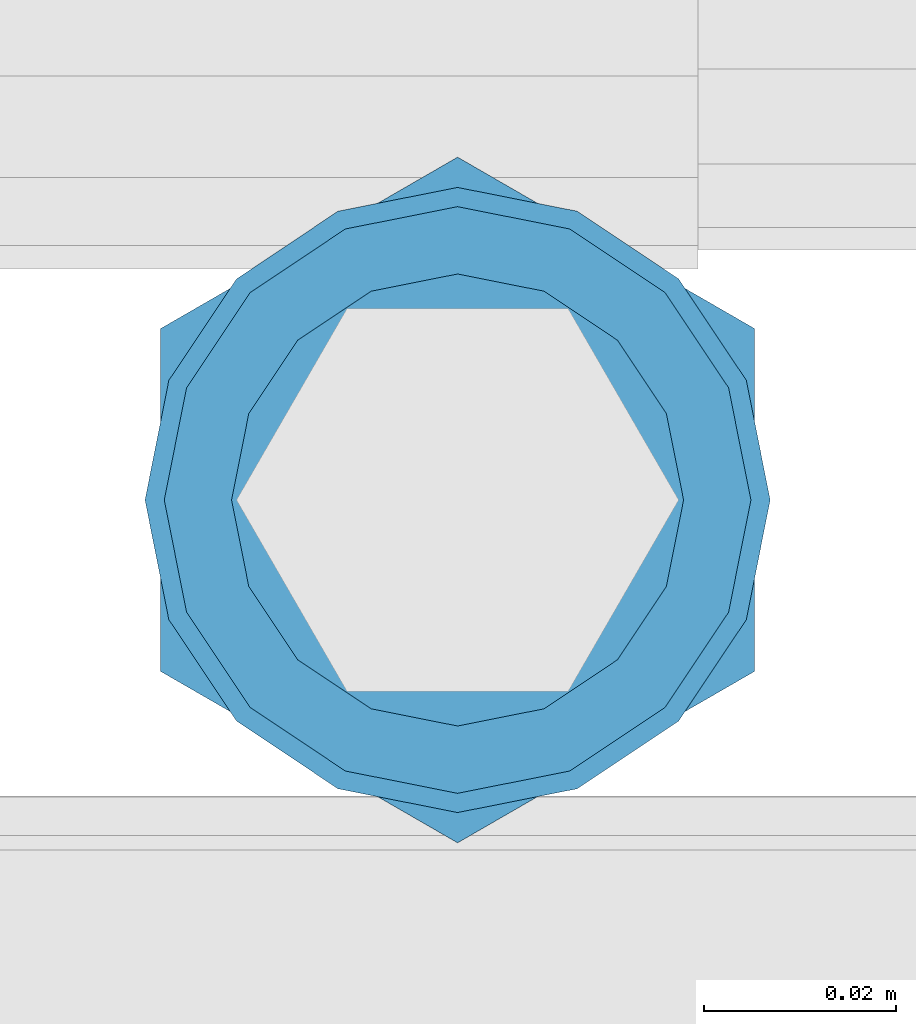
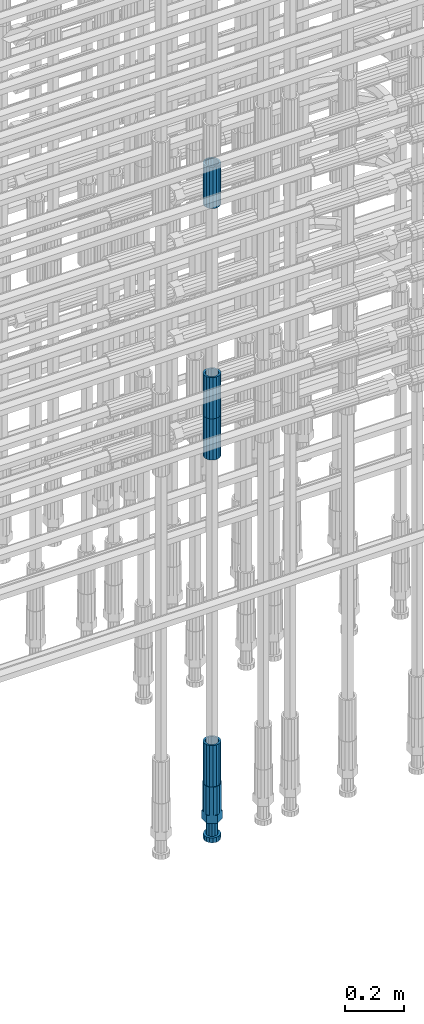
# One storey, part 21 of 119: 5 beams.
"""IFC2X3 building model written with IfcOpenShell, lengths in millimetres."""

import ifcopenshell
import ifcopenshell.guid

model = None  # the IFC model being written
_history = None  # IfcOwnerHistory: only IFC2X3 demands one
_inside = {}  # id of a spatial element -> (the spatial element, [elements in it])
_under = {}  # id of a project, library or spatial element -> (it, [spatial elements below it])
_declared = {}  # id of a project -> (the project, [libraries it declares])
_typed = {}  # id of a type object -> (the type object, [elements of that type])
_made_of = {}  # id of a material, layer set ... -> (it, [elements and type objects made of it])


def new_model(schema):
    """Start an empty IFC model of exactly this schema.

    Asked for "IFC4X3", IfcOpenShell would pick the latest addendum, in which some entities
    have other attributes; the version numbers below select the first issue.
    IFC2X3 requires an IfcOwnerHistory on every rooted entity: one is made here for all.
    """
    global model, _history
    if schema == "IFC4X3":
        model = ifcopenshell.file(schema_version=(4, 3, 0, 0))
    else:
        model = ifcopenshell.file(schema=schema)
    _inside.clear()
    _under.clear()
    _declared.clear()
    _typed.clear()
    _made_of.clear()
    _history = None
    if model.schema == "IFC2X3":
        org = make("IfcOrganization", Name="unknown")
        user = make(
            "IfcPersonAndOrganization",
            ThePerson=make("IfcPerson", FamilyName="unknown"),
            TheOrganization=org,
        )
        app = make(
            "IfcApplication",
            ApplicationDeveloper=org,
            Version="unknown",
            ApplicationFullName="unknown",
            ApplicationIdentifier="unknown",
        )
        _history = make(
            "IfcOwnerHistory",
            OwningUser=user,
            OwningApplication=app,
            ChangeAction="ADDED",
            CreationDate=0,
        )
    return model


def make(cls, **values):
    """One entity of the class cls with the attributes given. An attribute that is None is left unset."""
    return model.create_entity(
        cls, **{name: value for name, value in values.items() if value is not None}
    )


def rooted(cls, **values):
    """An entity with a GlobalId (a new one), such as an element, a storey or a relation."""
    return make(cls, GlobalId=ifcopenshell.guid.new(), OwnerHistory=_history, **values)


def si_unit(unit_type, name, prefix=None):
    """IfcSIUnit, for example si_unit("LENGTHUNIT", "METRE", prefix="MILLI")."""
    return make("IfcSIUnit", UnitType=unit_type, Prefix=prefix, Name=name)


def assignment(units):
    """IfcUnitAssignment: the units of a project."""
    return None if units is None else make("IfcUnitAssignment", Units=units)


def point(xyz):
    """IfcCartesianPoint."""
    return None if xyz is None else make("IfcCartesianPoint", Coordinates=xyz)


def direction(xyz):
    """IfcDirection."""
    return None if xyz is None else make("IfcDirection", DirectionRatios=xyz)


def frame(location, z_axis=None, x_axis=None):
    """IfcAxis2Placement3D, a coordinate frame: its origin and axes. An axis left out is left unset."""
    return make(
        "IfcAxis2Placement3D",
        Location=point(location),
        Axis=direction(z_axis),
        RefDirection=direction(x_axis),
    )


def origin_with_axes():
    """The frame at (0, 0, 0) with the z axis (0, 0, 1) and the x axis (1, 0, 0) written out."""
    return frame((0.0, 0.0, 0.0), z_axis=(0.0, 0.0, 1.0), x_axis=(1.0, 0.0, 0.0))


def place(relative_to, where):
    """IfcLocalPlacement: puts the frame where relative to a parent placement (None: the world)."""
    return make(
        "IfcLocalPlacement", PlacementRelTo=relative_to, RelativePlacement=where
    )


def context(
    kind, dimensions, precision=None, world=None, true_north=None, identifier=None
):
    """IfcGeometricRepresentationContext, for example the 3D "Model" context."""
    return make(
        "IfcGeometricRepresentationContext",
        ContextIdentifier=identifier,
        ContextType=kind,
        CoordinateSpaceDimension=dimensions,
        Precision=precision,
        WorldCoordinateSystem=world,
        TrueNorth=true_north,
    )


def subcontext(parent, identifier, kind, view, scale=None):
    """IfcGeometricRepresentationSubContext, for example "Body" below "Model"."""
    return make(
        "IfcGeometricRepresentationSubContext",
        ContextIdentifier=identifier,
        ContextType=kind,
        ParentContext=parent,
        TargetScale=scale,
        TargetView=view,
    )


def project(units=None, contexts=None):
    """IfcProject with its units and contexts."""
    return rooted(
        "IfcProject",
        Name="project",
        RepresentationContexts=contexts,
        UnitsInContext=assignment(units),
    )


def spatial(cls, under=None, at=None, **own):
    """A site, building, storey or space (cls), placed at a placement, below another one or the project."""
    s = rooted(cls, ObjectPlacement=at, **own)
    if under is not None:
        _under.setdefault(under.id(), (under, []))[1].append(s)
    return s


def faces_of(points, faces, orient=None, outer=None):
    """IfcFace entities. A face is a list of loops; a loop is a list of indices into points, from 0.

    orient and outer hold one flag for each loop. By default every Orientation is true, the
    first loop of a face is its IfcFaceOuterBound and the others are IfcFaceBound.
    """
    made = []
    for i, loops in enumerate(faces):
        bounds = []
        for j, loop in enumerate(loops):
            is_outer = j == 0 if outer is None else outer[i][j]
            bounds.append(
                make(
                    "IfcFaceOuterBound" if is_outer else "IfcFaceBound",
                    Bound=make("IfcPolyLoop", Polygon=[points[k] for k in loop]),
                    Orientation=True if orient is None else orient[i][j],
                )
            )
        made.append(make("IfcFace", Bounds=bounds))
    return made


def faceted_brep(points, faces, orient=None, outer=None, voids=None):
    """IfcFacetedBrep: a solid bounded by flat faces; with voids (closed shells), ...WithVoids."""
    shared = [point(p) for p in points]
    hull = make("IfcClosedShell", CfsFaces=faces_of(shared, faces, orient, outer))
    if voids is None:
        return make("IfcFacetedBrep", Outer=hull)
    return make(
        "IfcFacetedBrepWithVoids",
        Outer=hull,
        Voids=[
            make(cls, CfsFaces=faces_of(shared, fs, o, b)) for cls, fs, o, b in voids
        ],
    )


def shape(context_of_items, identifier, shape_type, items):
    """IfcShapeRepresentation: the items that make up one representation, for example the "Body"."""
    return make(
        "IfcShapeRepresentation",
        ContextOfItems=context_of_items,
        RepresentationIdentifier=identifier,
        RepresentationType=shape_type,
        Items=items,
    )


def material(Name=None, Category=None):
    """IfcMaterial."""
    return make("IfcMaterial", Name=Name, Category=Category)


def made_of(thing, what):
    """Note that an element or type object is made of a material, layer set ...; save() writes the relation."""
    if what is not None:
        _made_of.setdefault(what.id(), (what, []))[1].append(thing)
    return thing


def type_object(cls, material=None, **own):
    """A type object (cls), such as IfcWallType, which elements share."""
    return made_of(rooted(cls, **own), material)


def element(
    cls,
    number,
    at=None,
    inside=None,
    cuts=None,
    type_object=None,
    material=None,
    context=None,
    identifier="Body",
    shape_type=None,
    held_by="IfcProductDefinitionShape",
    body=None,
    shapes=None,
    **own,
):
    """One element of the class cls, such as IfcWall. Its Tag is "e" and its number.

    at: its placement. inside: the storey or other place that contains it. cuts: it is an
    opening in that element (IfcRelVoidsElement). A single representation is given by context,
    identifier, shape_type and body (its items); several are given by shapes. held_by: the class
    of the entity that holds the representations. save() writes the other relations.
    """
    e = rooted(cls, Tag="e%d" % number, ObjectPlacement=at, **own)
    if body is not None:
        shapes = [shape(context, identifier, shape_type, body)]
    if shapes is not None:
        e.Representation = make(held_by, Representations=shapes)
    if inside is not None:
        _inside.setdefault(inside.id(), (inside, []))[1].append(e)
    if cuts is not None:
        rooted(
            "IfcRelVoidsElement", RelatingBuildingElement=cuts, RelatedOpeningElement=e
        )
    if type_object is not None:
        _typed.setdefault(type_object.id(), (type_object, []))[1].append(e)
    return made_of(e, material)


def aggregate(whole, parts):
    """IfcRelAggregates: a whole, such as a stair, and the parts it consists of."""
    return rooted("IfcRelAggregates", RelatingObject=whole, RelatedObjects=parts)


def save(model, path):
    """Write the relations noted so far, then the file.

    IfcRelAggregates (storeys below a building ...), IfcRelContainedInSpatialStructure (elements
    in a storey), IfcRelDefinesByType, IfcRelAssociatesMaterial and IfcRelDeclares: one each for
    every whole, place, type object, material and project.
    """
    for whole, parts in _under.values():
        aggregate(whole, parts)
    for where, things in _inside.values():
        rooted(
            "IfcRelContainedInSpatialStructure",
            RelatedElements=things,
            RelatingStructure=where,
        )
    for kind, things in _typed.values():
        rooted("IfcRelDefinesByType", RelatedObjects=things, RelatingType=kind)
    for what, things in _made_of.values():
        rooted("IfcRelAssociatesMaterial", RelatedObjects=things, RelatingMaterial=what)
    for by, libraries in _declared.values():
        rooted("IfcRelDeclares", RelatingContext=by, RelatedDefinitions=libraries)
    model.write(path)


model = new_model("IFC2X3")

# Units and contexts
model_context = context("Model", 3, precision=1e-05, world=origin_with_axes())
body_context = subcontext(model_context, "Body", "Model", "MODEL_VIEW")
ifc_project = project(units=[si_unit("LENGTHUNIT", "METRE", prefix="MILLI"), si_unit("AREAUNIT", "SQUARE_METRE"), si_unit("VOLUMEUNIT", "CUBIC_METRE"), si_unit("MASSUNIT", "GRAM", prefix="KILO"), si_unit("TIMEUNIT", "SECOND"), si_unit("PLANEANGLEUNIT", "RADIAN"), si_unit("SOLIDANGLEUNIT", "STERADIAN"), si_unit("THERMODYNAMICTEMPERATUREUNIT", "DEGREE_CELSIUS"), si_unit("LUMINOUSINTENSITYUNIT", "LUMEN")], contexts=[model_context])

# Site, building, storey
site_placement = place(None, origin_with_axes())
site = spatial("IfcSite", under=ifc_project, at=site_placement, CompositionType="ELEMENT")
building_placement = place(site_placement, origin_with_axes())
building = spatial("IfcBuilding", under=site, at=building_placement, Name="Undefined", CompositionType="ELEMENT")
storey_placement = place(building_placement, origin_with_axes())
storey = spatial("IfcBuildingStorey", under=building, at=storey_placement, Name="Undefined", CompositionType="ELEMENT", Elevation=0.0)

# Beams
ifc_material = material(Name="STEEL/S275")
beam_type_1 = type_object("IfcBeamType", PredefinedType="NOTDEFINED")
beam_1_placement = place(storey_placement, frame((2035325.00639737, 6205153.78099914, 19667.7157291641), z_axis=(1.0, 0.0, 0.0), x_axis=(0.0, 0.0, 1.0)))
element("IfcBeam", 1, at=beam_1_placement, inside=storey, type_object=beam_type_1, material=ifc_material, Name="AG40N", context=body_context, shape_type="Brep", body=[
    faceted_brep([(1.62981450557709e-09, -23.4999999990687, 0.0), (7.45058059692383e-09, -21.7111690142192, 8.99306066057534), (170.000002125278, -21.711168999318, 8.99306066022245), (170.000002127141, -23.4999999844003, -3.66071617463604e-10), (4.65661287307739e-09, -16.6170093587134, 16.6170093578889), (170.000002122484, -16.6170093440451, 16.6170093575288), (1.86264514923096e-09, -8.99306066217832, 21.7111690140277), (170.000002118759, -8.99306064750999, 21.7111690136603), (2.3283064365387e-10, 9.31322574615479e-10, 23.5), (170.000002114102, 1.28056854009628e-08, 23.4999999996485), (-6.51925802230835e-09, 8.99306065868586, 21.7111690140241), (170.00000211224, 8.99306067335419, 21.7111690136639), (-7.45058059692383e-09, 16.6170093561523, 16.6170093578853), (170.000002109446, 16.6170093708206, 16.6170093575324), (-9.31322574615479e-09, 21.711169013055, 8.99306066057534), (170.000002108514, 21.7111690277234, 8.99306066022245), (-1.16415321826935e-09, 23.5000000009313, 0.0), (170.000002108514, 23.5000000144355, -3.66071617463604e-10), (-8.38190317153931e-09, 21.7111690151505, -8.99306066059444), (170.000002110377, 21.7111690300517, -8.9930606609546), (-5.58793544769287e-09, 16.6170093598776, -16.6170093579008), (170.000002113171, 16.6170093745459, -16.6170093582609), (-9.31322574615479e-10, 8.99306066334248, -21.7111690140396), (170.000002115965, 8.99306067801081, -21.7111690143961), (2.3283064365387e-10, 9.31322574615479e-10, -23.5), (170.00000211969, 1.7927959561348e-08, -23.5000000003843), (5.58793544769287e-09, -8.99306065752171, -21.7111690140396), (170.000002123415, -8.99306064285338, -21.7111690143961), (8.38190317153931e-09, -16.6170093549881, -16.6170093579008), (170.000002125278, -16.6170093403198, -16.6170093582646), (9.31322574615479e-09, -21.7111690121237, -8.99306066059444), (170.000002127141, -21.7111689972226, -8.9930606609546), (1.11758708953857e-08, -30.4999999990687, -9.54969436861575e-12), (1.30385160446167e-08, -28.1783257392235, -11.6718446871514), (170.000002129003, -28.1783257243223, -11.6718446875116), (170.000002129935, -30.4999999841675, -3.66071617463604e-10), (1.02445483207703e-08, -21.5667568228673, -21.5667568262129), (170.000002128072, -21.566756808199, -21.5667568265694), (7.45058059692383e-09, -11.6718446831219, -28.1783257416196), (170.000002125278, -11.6718446684536, -28.1783257419834), (3.72529029846191e-09, 3.95812094211578e-09, -30.5000000000277), (170.00000211969, 1.83936208486557e-08, -30.5000000003879), (-9.31322574615479e-10, 11.6718446905725, -28.1783257416232), (170.000002115965, 11.6718447052408, -28.1783257419797), (-6.51925802230835e-09, 21.5667568286881, -21.5667568262093), (170.000002110377, 21.5667568433564, -21.5667568265694), (-9.31322574615479e-09, 28.178325742716, -11.6718446871478), (170.000002108514, 28.1783257573843, -11.6718446875079), (-1.21071934700012e-08, 30.5, -5.91171556152403e-12), (170.000002106652, 30.5000000144355, -3.62433638656512e-10), (-1.21071934700012e-08, 28.1783257401548, 11.6718446871359), (170.00000210572, 28.1783257548232, 11.6718446867794), (-1.02445483207703e-08, 21.5667568240315, 21.5667568261974), (170.000002107583, 21.566756838467, 21.5667568258409), (-7.45058059692383e-09, 11.671844684286, 28.1783257416041), (170.000002110377, 11.6718446989544, 28.178325741244), (-2.79396772384644e-09, -2.56113708019257e-09, 30.5000000000159), (170.000002114102, 1.18743628263474e-08, 30.4999999996558), (1.86264514923096e-09, -11.6718446896411, 28.1783257416114), (170.000002118759, -11.67184467474, 28.178325741244), (7.45058059692383e-09, -21.5667568275239, 21.5667568261974), (170.000002123415, -21.5667568126228, 21.5667568258373), (1.02445483207703e-08, -28.1783257415518, 11.6718446871359), (170.000002127141, -28.1783257271163, 11.6718446867794)], [[[0, 1, 2, 3]], [[1, 4, 5, 2]], [[4, 6, 7, 5]], [[6, 8, 9, 7]], [[8, 10, 11, 9]], [[10, 12, 13, 11]], [[12, 14, 15, 13]], [[14, 16, 17, 15]], [[16, 18, 19, 17]], [[18, 20, 21, 19]], [[20, 22, 23, 21]], [[22, 24, 25, 23]], [[24, 26, 27, 25]], [[26, 28, 29, 27]], [[28, 30, 31, 29]], [[30, 0, 3, 31]], [[32, 33, 34, 35]], [[33, 36, 37, 34]], [[36, 38, 39, 37]], [[38, 40, 41, 39]], [[40, 42, 43, 41]], [[42, 44, 45, 43]], [[44, 46, 47, 45]], [[46, 48, 49, 47]], [[48, 50, 51, 49]], [[50, 52, 53, 51]], [[52, 54, 55, 53]], [[54, 56, 57, 55]], [[56, 58, 59, 57]], [[58, 60, 61, 59]], [[60, 62, 63, 61]], [[62, 32, 35, 63]], [[37, 39, 41, 43, 45, 47, 49, 51, 53, 55, 57, 59, 61, 63, 35, 34], [5, 7, 9, 11, 13, 15, 17, 19, 21, 23, 25, 27, 29, 31, 3, 2]], [[62, 60, 58, 56, 54, 52, 50, 48, 46, 44, 42, 40, 38, 36, 33, 32], [30, 28, 26, 24, 22, 20, 18, 16, 14, 12, 10, 8, 6, 4, 1, 0]]]),
])
beam_2_placement = place(storey_placement, frame((2035325.00639737, 6205153.78099914, 18490.9668583149), z_axis=(-0.99999999999998, 1.98000110685822e-07, 0.0), x_axis=(0.0, 0.0, -1.0)))
element("IfcBeam", 2, at=beam_2_placement, inside=storey, type_object=beam_type_1, material=ifc_material, Name="AG40N", context=body_context, shape_type="Brep", body=[
    faceted_brep([(1.62981450557709e-09, -23.4999999990687, 0.0), (7.45058059692383e-09, -21.7111690142192, 8.99306066057534), (170.000002125278, -21.711168999318, 8.99306066022245), (170.000002127141, -23.4999999844003, -3.66071617463604e-10), (4.65661287307739e-09, -16.6170093587134, 16.6170093578889), (170.000002122484, -16.6170093440451, 16.6170093575288), (1.86264514923096e-09, -8.99306066217832, 21.7111690140277), (170.000002118759, -8.99306064750999, 21.7111690136603), (2.3283064365387e-10, 9.31322574615479e-10, 23.5), (170.000002114102, 1.28056854009628e-08, 23.4999999996485), (-6.51925802230835e-09, 8.99306065868586, 21.7111690140241), (170.00000211224, 8.99306067335419, 21.7111690136639), (-7.45058059692383e-09, 16.6170093561523, 16.6170093578853), (170.000002109446, 16.6170093708206, 16.6170093575324), (-9.31322574615479e-09, 21.711169013055, 8.99306066057534), (170.000002108514, 21.7111690277234, 8.99306066022245), (-1.16415321826935e-09, 23.5000000009313, 0.0), (170.000002108514, 23.5000000144355, -3.66071617463604e-10), (-8.38190317153931e-09, 21.7111690151505, -8.99306066059444), (170.000002110377, 21.7111690300517, -8.9930606609546), (-5.58793544769287e-09, 16.6170093598776, -16.6170093579008), (170.000002113171, 16.6170093745459, -16.6170093582609), (-9.31322574615479e-10, 8.99306066334248, -21.7111690140396), (170.000002115965, 8.99306067801081, -21.7111690143961), (2.3283064365387e-10, 9.31322574615479e-10, -23.5), (170.00000211969, 1.7927959561348e-08, -23.5000000003843), (5.58793544769287e-09, -8.99306065752171, -21.7111690140396), (170.000002123415, -8.99306064285338, -21.7111690143961), (8.38190317153931e-09, -16.6170093549881, -16.6170093579008), (170.000002125278, -16.6170093403198, -16.6170093582646), (9.31322574615479e-09, -21.7111690121237, -8.99306066059444), (170.000002127141, -21.7111689972226, -8.9930606609546), (1.11758708953857e-08, -30.4999999990687, -9.54969436861575e-12), (1.30385160446167e-08, -28.1783257392235, -11.6718446871514), (170.000002129003, -28.1783257243223, -11.6718446875116), (170.000002129935, -30.4999999841675, -3.66071617463604e-10), (1.02445483207703e-08, -21.5667568228673, -21.5667568262129), (170.000002128072, -21.566756808199, -21.5667568265694), (7.45058059692383e-09, -11.6718446831219, -28.1783257416196), (170.000002125278, -11.6718446684536, -28.1783257419834), (3.72529029846191e-09, 3.95812094211578e-09, -30.5000000000277), (170.00000211969, 1.83936208486557e-08, -30.5000000003879), (-9.31322574615479e-10, 11.6718446905725, -28.1783257416232), (170.000002115965, 11.6718447052408, -28.1783257419797), (-6.51925802230835e-09, 21.5667568286881, -21.5667568262093), (170.000002110377, 21.5667568433564, -21.5667568265694), (-9.31322574615479e-09, 28.178325742716, -11.6718446871478), (170.000002108514, 28.1783257573843, -11.6718446875079), (-1.21071934700012e-08, 30.5, -5.91171556152403e-12), (170.000002106652, 30.5000000144355, -3.62433638656512e-10), (-1.21071934700012e-08, 28.1783257401548, 11.6718446871359), (170.00000210572, 28.1783257548232, 11.6718446867794), (-1.02445483207703e-08, 21.5667568240315, 21.5667568261974), (170.000002107583, 21.566756838467, 21.5667568258409), (-7.45058059692383e-09, 11.671844684286, 28.1783257416041), (170.000002110377, 11.6718446989544, 28.178325741244), (-2.79396772384644e-09, -2.56113708019257e-09, 30.5000000000159), (170.000002114102, 1.18743628263474e-08, 30.4999999996558), (1.86264514923096e-09, -11.6718446896411, 28.1783257416114), (170.000002118759, -11.67184467474, 28.178325741244), (7.45058059692383e-09, -21.5667568275239, 21.5667568261974), (170.000002123415, -21.5667568126228, 21.5667568258373), (1.02445483207703e-08, -28.1783257415518, 11.6718446871359), (170.000002127141, -28.1783257271163, 11.6718446867794)], [[[0, 1, 2, 3]], [[1, 4, 5, 2]], [[4, 6, 7, 5]], [[6, 8, 9, 7]], [[8, 10, 11, 9]], [[10, 12, 13, 11]], [[12, 14, 15, 13]], [[14, 16, 17, 15]], [[16, 18, 19, 17]], [[18, 20, 21, 19]], [[20, 22, 23, 21]], [[22, 24, 25, 23]], [[24, 26, 27, 25]], [[26, 28, 29, 27]], [[28, 30, 31, 29]], [[30, 0, 3, 31]], [[32, 33, 34, 35]], [[33, 36, 37, 34]], [[36, 38, 39, 37]], [[38, 40, 41, 39]], [[40, 42, 43, 41]], [[42, 44, 45, 43]], [[44, 46, 47, 45]], [[46, 48, 49, 47]], [[48, 50, 51, 49]], [[50, 52, 53, 51]], [[52, 54, 55, 53]], [[54, 56, 57, 55]], [[56, 58, 59, 57]], [[58, 60, 61, 59]], [[60, 62, 63, 61]], [[62, 32, 35, 63]], [[37, 39, 41, 43, 45, 47, 49, 51, 53, 55, 57, 59, 61, 63, 35, 34], [5, 7, 9, 11, 13, 15, 17, 19, 21, 23, 25, 27, 29, 31, 3, 2]], [[62, 60, 58, 56, 54, 52, 50, 48, 46, 44, 42, 40, 38, 36, 33, 32], [30, 28, 26, 24, 22, 20, 18, 16, 14, 12, 10, 8, 6, 4, 1, 0]]]),
])
beam_3_placement = place(storey_placement, frame((2035325.00639737, 6205153.78099914, 20704.6057291641), z_axis=(1.0, 0.0, 0.0), x_axis=(0.0, 0.0, 1.0)))
element("IfcBeam", 3, at=beam_3_placement, inside=storey, type_object=beam_type_1, material=ifc_material, Name="AG40N", context=body_context, shape_type="Brep", body=[
    faceted_brep([(1.62981450557709e-09, -23.4999999990687, 0.0), (7.45058059692383e-09, -21.7111690142192, 8.99306066057534), (170.000002125278, -21.711168999318, 8.99306066022245), (170.000002127141, -23.4999999844003, -3.66071617463604e-10), (4.65661287307739e-09, -16.6170093587134, 16.6170093578889), (170.000002122484, -16.6170093440451, 16.6170093575288), (1.86264514923096e-09, -8.99306066217832, 21.7111690140277), (170.000002118759, -8.99306064750999, 21.7111690136603), (2.3283064365387e-10, 9.31322574615479e-10, 23.5), (170.000002114102, 1.28056854009628e-08, 23.4999999996485), (-6.51925802230835e-09, 8.99306065868586, 21.7111690140241), (170.00000211224, 8.99306067335419, 21.7111690136639), (-7.45058059692383e-09, 16.6170093561523, 16.6170093578853), (170.000002109446, 16.6170093708206, 16.6170093575324), (-9.31322574615479e-09, 21.711169013055, 8.99306066057534), (170.000002108514, 21.7111690277234, 8.99306066022245), (-1.16415321826935e-09, 23.5000000009313, 0.0), (170.000002108514, 23.5000000144355, -3.66071617463604e-10), (-8.38190317153931e-09, 21.7111690151505, -8.99306066059444), (170.000002110377, 21.7111690300517, -8.9930606609546), (-5.58793544769287e-09, 16.6170093598776, -16.6170093579008), (170.000002113171, 16.6170093745459, -16.6170093582609), (-9.31322574615479e-10, 8.99306066334248, -21.7111690140396), (170.000002115965, 8.99306067801081, -21.7111690143961), (2.3283064365387e-10, 9.31322574615479e-10, -23.5), (170.00000211969, 1.7927959561348e-08, -23.5000000003843), (5.58793544769287e-09, -8.99306065752171, -21.7111690140396), (170.000002123415, -8.99306064285338, -21.7111690143961), (8.38190317153931e-09, -16.6170093549881, -16.6170093579008), (170.000002125278, -16.6170093403198, -16.6170093582646), (9.31322574615479e-09, -21.7111690121237, -8.99306066059444), (170.000002127141, -21.7111689972226, -8.9930606609546), (1.11758708953857e-08, -30.4999999990687, -9.54969436861575e-12), (1.30385160446167e-08, -28.1783257392235, -11.6718446871514), (170.000002129003, -28.1783257243223, -11.6718446875116), (170.000002129935, -30.4999999841675, -3.66071617463604e-10), (1.02445483207703e-08, -21.5667568228673, -21.5667568262129), (170.000002128072, -21.566756808199, -21.5667568265694), (7.45058059692383e-09, -11.6718446831219, -28.1783257416196), (170.000002125278, -11.6718446684536, -28.1783257419834), (3.72529029846191e-09, 3.95812094211578e-09, -30.5000000000277), (170.00000211969, 1.83936208486557e-08, -30.5000000003879), (-9.31322574615479e-10, 11.6718446905725, -28.1783257416232), (170.000002115965, 11.6718447052408, -28.1783257419797), (-6.51925802230835e-09, 21.5667568286881, -21.5667568262093), (170.000002110377, 21.5667568433564, -21.5667568265694), (-9.31322574615479e-09, 28.178325742716, -11.6718446871478), (170.000002108514, 28.1783257573843, -11.6718446875079), (-1.21071934700012e-08, 30.5, -5.91171556152403e-12), (170.000002106652, 30.5000000144355, -3.62433638656512e-10), (-1.21071934700012e-08, 28.1783257401548, 11.6718446871359), (170.00000210572, 28.1783257548232, 11.6718446867794), (-1.02445483207703e-08, 21.5667568240315, 21.5667568261974), (170.000002107583, 21.566756838467, 21.5667568258409), (-7.45058059692383e-09, 11.671844684286, 28.1783257416041), (170.000002110377, 11.6718446989544, 28.178325741244), (-2.79396772384644e-09, -2.56113708019257e-09, 30.5000000000159), (170.000002114102, 1.18743628263474e-08, 30.4999999996558), (1.86264514923096e-09, -11.6718446896411, 28.1783257416114), (170.000002118759, -11.67184467474, 28.178325741244), (7.45058059692383e-09, -21.5667568275239, 21.5667568261974), (170.000002123415, -21.5667568126228, 21.5667568258373), (1.02445483207703e-08, -28.1783257415518, 11.6718446871359), (170.000002127141, -28.1783257271163, 11.6718446867794)], [[[0, 1, 2, 3]], [[1, 4, 5, 2]], [[4, 6, 7, 5]], [[6, 8, 9, 7]], [[8, 10, 11, 9]], [[10, 12, 13, 11]], [[12, 14, 15, 13]], [[14, 16, 17, 15]], [[16, 18, 19, 17]], [[18, 20, 21, 19]], [[20, 22, 23, 21]], [[22, 24, 25, 23]], [[24, 26, 27, 25]], [[26, 28, 29, 27]], [[28, 30, 31, 29]], [[30, 0, 3, 31]], [[32, 33, 34, 35]], [[33, 36, 37, 34]], [[36, 38, 39, 37]], [[38, 40, 41, 39]], [[40, 42, 43, 41]], [[42, 44, 45, 43]], [[44, 46, 47, 45]], [[46, 48, 49, 47]], [[48, 50, 51, 49]], [[50, 52, 53, 51]], [[52, 54, 55, 53]], [[54, 56, 57, 55]], [[56, 58, 59, 57]], [[58, 60, 61, 59]], [[60, 62, 63, 61]], [[62, 32, 35, 63]], [[37, 39, 41, 43, 45, 47, 49, 51, 53, 55, 57, 59, 61, 63, 35, 34], [5, 7, 9, 11, 13, 15, 17, 19, 21, 23, 25, 27, 29, 31, 3, 2]], [[62, 60, 58, 56, 54, 52, 50, 48, 46, 44, 42, 40, 38, 36, 33, 32], [30, 28, 26, 24, 22, 20, 18, 16, 14, 12, 10, 8, 6, 4, 1, 0]]]),
])
beam_4_placement = place(storey_placement, frame((2035325.00639737, 6205153.78099914, 20007.7168583149), z_axis=(-0.99999999999998, 1.98000110685822e-07, 0.0), x_axis=(0.0, 0.0, -1.0)))
element("IfcBeam", 4, at=beam_4_placement, inside=storey, type_object=beam_type_1, material=ifc_material, Name="AG40N", context=body_context, shape_type="Brep", body=[
    faceted_brep([(1.62981450557709e-09, -23.4999999990687, 0.0), (7.45058059692383e-09, -21.7111690142192, 8.99306066057534), (170.000002125278, -21.711168999318, 8.99306066022245), (170.000002127141, -23.4999999844003, -3.66071617463604e-10), (4.65661287307739e-09, -16.6170093587134, 16.6170093578889), (170.000002122484, -16.6170093440451, 16.6170093575288), (1.86264514923096e-09, -8.99306066217832, 21.7111690140277), (170.000002118759, -8.99306064750999, 21.7111690136603), (2.3283064365387e-10, 9.31322574615479e-10, 23.5), (170.000002114102, 1.28056854009628e-08, 23.4999999996485), (-6.51925802230835e-09, 8.99306065868586, 21.7111690140241), (170.00000211224, 8.99306067335419, 21.7111690136639), (-7.45058059692383e-09, 16.6170093561523, 16.6170093578853), (170.000002109446, 16.6170093708206, 16.6170093575324), (-9.31322574615479e-09, 21.711169013055, 8.99306066057534), (170.000002108514, 21.7111690277234, 8.99306066022245), (-1.16415321826935e-09, 23.5000000009313, 0.0), (170.000002108514, 23.5000000144355, -3.66071617463604e-10), (-8.38190317153931e-09, 21.7111690151505, -8.99306066059444), (170.000002110377, 21.7111690300517, -8.9930606609546), (-5.58793544769287e-09, 16.6170093598776, -16.6170093579008), (170.000002113171, 16.6170093745459, -16.6170093582609), (-9.31322574615479e-10, 8.99306066334248, -21.7111690140396), (170.000002115965, 8.99306067801081, -21.7111690143961), (2.3283064365387e-10, 9.31322574615479e-10, -23.5), (170.00000211969, 1.7927959561348e-08, -23.5000000003843), (5.58793544769287e-09, -8.99306065752171, -21.7111690140396), (170.000002123415, -8.99306064285338, -21.7111690143961), (8.38190317153931e-09, -16.6170093549881, -16.6170093579008), (170.000002125278, -16.6170093403198, -16.6170093582646), (9.31322574615479e-09, -21.7111690121237, -8.99306066059444), (170.000002127141, -21.7111689972226, -8.9930606609546), (1.11758708953857e-08, -30.4999999990687, -9.54969436861575e-12), (1.30385160446167e-08, -28.1783257392235, -11.6718446871514), (170.000002129003, -28.1783257243223, -11.6718446875116), (170.000002129935, -30.4999999841675, -3.66071617463604e-10), (1.02445483207703e-08, -21.5667568228673, -21.5667568262129), (170.000002128072, -21.566756808199, -21.5667568265694), (7.45058059692383e-09, -11.6718446831219, -28.1783257416196), (170.000002125278, -11.6718446684536, -28.1783257419834), (3.72529029846191e-09, 3.95812094211578e-09, -30.5000000000277), (170.00000211969, 1.83936208486557e-08, -30.5000000003879), (-9.31322574615479e-10, 11.6718446905725, -28.1783257416232), (170.000002115965, 11.6718447052408, -28.1783257419797), (-6.51925802230835e-09, 21.5667568286881, -21.5667568262093), (170.000002110377, 21.5667568433564, -21.5667568265694), (-9.31322574615479e-09, 28.178325742716, -11.6718446871478), (170.000002108514, 28.1783257573843, -11.6718446875079), (-1.21071934700012e-08, 30.5, -5.91171556152403e-12), (170.000002106652, 30.5000000144355, -3.62433638656512e-10), (-1.21071934700012e-08, 28.1783257401548, 11.6718446871359), (170.00000210572, 28.1783257548232, 11.6718446867794), (-1.02445483207703e-08, 21.5667568240315, 21.5667568261974), (170.000002107583, 21.566756838467, 21.5667568258409), (-7.45058059692383e-09, 11.671844684286, 28.1783257416041), (170.000002110377, 11.6718446989544, 28.178325741244), (-2.79396772384644e-09, -2.56113708019257e-09, 30.5000000000159), (170.000002114102, 1.18743628263474e-08, 30.4999999996558), (1.86264514923096e-09, -11.6718446896411, 28.1783257416114), (170.000002118759, -11.67184467474, 28.178325741244), (7.45058059692383e-09, -21.5667568275239, 21.5667568261974), (170.000002123415, -21.5667568126228, 21.5667568258373), (1.02445483207703e-08, -28.1783257415518, 11.6718446871359), (170.000002127141, -28.1783257271163, 11.6718446867794)], [[[0, 1, 2, 3]], [[1, 4, 5, 2]], [[4, 6, 7, 5]], [[6, 8, 9, 7]], [[8, 10, 11, 9]], [[10, 12, 13, 11]], [[12, 14, 15, 13]], [[14, 16, 17, 15]], [[16, 18, 19, 17]], [[18, 20, 21, 19]], [[20, 22, 23, 21]], [[22, 24, 25, 23]], [[24, 26, 27, 25]], [[26, 28, 29, 27]], [[28, 30, 31, 29]], [[30, 0, 3, 31]], [[32, 33, 34, 35]], [[33, 36, 37, 34]], [[36, 38, 39, 37]], [[38, 40, 41, 39]], [[40, 42, 43, 41]], [[42, 44, 45, 43]], [[44, 46, 47, 45]], [[46, 48, 49, 47]], [[48, 50, 51, 49]], [[50, 52, 53, 51]], [[52, 54, 55, 53]], [[54, 56, 57, 55]], [[56, 58, 59, 57]], [[58, 60, 61, 59]], [[60, 62, 63, 61]], [[62, 32, 35, 63]], [[37, 39, 41, 43, 45, 47, 49, 51, 53, 55, 57, 59, 61, 63, 35, 34], [5, 7, 9, 11, 13, 15, 17, 19, 21, 23, 25, 27, 29, 31, 3, 2]], [[62, 60, 58, 56, 54, 52, 50, 48, 46, 44, 42, 40, 38, 36, 33, 32], [30, 28, 26, 24, 22, 20, 18, 16, 14, 12, 10, 8, 6, 4, 1, 0]]]),
])
beam_type_2 = type_object("IfcBeamType", Name="ROD65", PredefinedType="NOTDEFINED")
beam_5_placement = place(storey_placement, frame((2035325.00639737, 6205153.78099914, 18320.9668583149), z_axis=(-0.99999999999998, 1.98000110685822e-07, 0.0), x_axis=(0.0, 0.0, -1.0)))
element("IfcBeam", 5, at=beam_5_placement, inside=storey, type_object=beam_type_2, material=ifc_material, Name="AGB40", ObjectType="ROD65", context=body_context, shape_type="Brep", body=[
    faceted_brep([(116.999999999069, 17.8249999252148, 30.8738056446964), (116.999999998137, 22.0056957420893, 23.632628078838), (116.999999999069, 12.4372115600854, 30.0260848066173), (116.999999999069, 8.17543111252598, 30.8738056446964), (117.000000000931, -17.8250000746921, 30.8738056446964), (150.200000001118, -17.8250000723638, 30.8738056446964), (150.199999999255, 17.8249999275431, 30.8738056446964), (117.000000000931, -8.17543109622784, 30.8738056446964), (117.000000001863, -22.0056959956419, 23.6326278985034), (117.000000000931, -12.4372115437873, 30.0260848066173), (117.000000001863, -35.6500000746455, -2.18278728425503e-10), (150.200000002049, -35.6500000723172, -2.18278728425503e-10), (117.000000001863, -30.8443149488885, 8.32369080289209), (117.000000001863, -30.8443149488885, -8.32369080355784), (117.000000002794, -32.4999999918509, 0.0), (117.000000000931, -17.8250000746921, -30.873805645133), (150.200000001118, -17.8250000723638, -30.873805645133), (117.000000001863, -22.0056959961075, -23.6326278982269), (117.000000000931, -8.17543109389953, -30.873805645133), (117.000000000931, -12.4372115437873, -30.0260848066173), (116.999999999069, 17.8249999252148, -30.873805645133), (150.199999999255, 17.8249999275431, -30.873805645133), (116.999999999069, 8.17543111019768, -30.873805645133), (116.999999999069, 12.4372115600854, -30.0260848066173), (116.999999998137, 22.005695742555, -23.6326280785652), (116.999999998137, 35.6499999251682, -2.18278728425503e-10), (150.199999998324, 35.6499999277294, -2.18278728425503e-10), (116.999999998137, 30.8443150522653, -8.32369036550881), (116.999999997206, 32.5000000081491, 0.0), (116.999999998137, 30.8443150522653, 8.32369036483942), (1.86264514923096e-09, -22.9809703885112, 22.9809703885621), (1.86264514923096e-09, -30.0260848065373, 12.4372115518672), (117.000000001863, -30.0260847983882, 12.4372115518672), (117.000000001863, -22.9809703803621, 22.9809703885621), (-1.86264514923096e-09, 22.9809703885112, -22.9809703885621), (-1.86264514923096e-09, 30.0260848065373, -12.4372115518672), (116.999999998137, 30.0260848146863, -12.4372115518672), (116.999999998137, 22.9809703966603, -22.9809703885621), (1.86264514923096e-09, -30.0260848065373, -12.4372115518672), (1.86264514923096e-09, -22.9809703885112, -22.9809703885621), (117.000000001863, -22.9809703803621, -22.9809703885621), (117.000000001863, -30.0260847983882, -12.4372115518672), (9.31322574615479e-10, -12.4372115519363, 30.0260848066173), (0.0, 0.0, 32.5), (-9.31322574615479e-10, 12.4372115519363, 30.0260848066173), (-1.86264514923096e-09, 22.9809703885112, 22.9809703885621), (-1.86264514923096e-09, 30.0260848065373, 12.4372115518672), (-2.79396772384644e-09, 32.5, 0.0), (-9.31322574615479e-10, 12.4372115519363, -30.0260848066173), (0.0, 0.0, -32.5), (9.31322574615479e-10, -12.4372115519363, -30.0260848066173), (2.79396772384644e-09, -32.5, 0.0), (116.999999998137, 22.9809703966603, 22.9809703885621), (116.999999998137, 30.0260848146863, 12.4372115518672), (117.0, 8.14907252788544e-09, -32.5), (117.0, 8.14907252788544e-09, 32.5), (150.200000000186, -10.5000000959262, 18.1865334791873), (150.199999999255, -9.59262251853943e-08, 20.9999999997126), (150.199999998324, 10.4999999040738, 18.1865334791873), (150.199999997392, 18.1865333835594, 10.4999999997126), (150.199999997392, 20.9999999040738, -2.87400325760245e-10), (150.199999997392, 18.1865333835594, -10.5000000002874), (150.199999998324, 10.4999999040738, -18.1865334797621), (150.199999999255, -9.59262251853943e-08, -21.0000000002874), (150.200000000186, -10.5000000959262, -18.1865334797621), (150.200000000186, -18.1865335754119, -10.5000000002874), (150.200000001118, -21.0000000959262, -2.87400325760245e-10), (150.200000000186, -18.1865335754119, 10.4999999997126), (210.979999999516, 10.4999999082647, 18.1865334791873), (210.979999999516, -9.17352735996246e-08, 20.9999999997126), (210.979999997653, 18.1865333877504, 10.4999999997126), (210.979999997653, 20.9999999082647, -2.87400325760245e-10), (210.979999997653, 18.1865333877504, -10.5000000002874), (210.979999999516, 10.4999999082647, -18.1865334797621), (210.979999999516, -9.17352735996246e-08, -21.0000000002874), (210.979999999516, -10.5000000917353, -18.1865334797621), (210.980000000447, -18.1865335712209, -10.5000000002874), (210.980000001378, -21.0000000917353, -2.87400325760245e-10), (210.980000000447, -18.1865335712209, 10.4999999997126), (210.979999999516, -10.5000000917353, 18.1865334791873), (211.001368402503, -27.7269939335529, -11.4911163272045), (211.003082515672, -21.2238095656503, -21.2238154190527), (231.002518340945, -21.2131946226582, -21.2132004554769), (231.000804228708, -27.7163789905608, -11.4805013636287), (211.001368415542, -11.4911086384673, -27.7269970399575), (231.000804241747, -11.4804936954752, -27.7163820763781), (210.996487061493, -0.0106066407170147, -30.0106107396168), (230.995922887698, 8.30227509140968e-06, -29.999995776041), (210.98918159306, 11.4698940692469, -27.7269970332745), (230.988617419265, 11.4805090120062, -27.7163820696951), (210.980564201251, 21.2025913291145, -21.2238154067054), (230.980000027455, 21.2132062721066, -21.2132004431296), (210.971946807578, 27.7057702087332, -11.4911163110701), (230.971382633783, 27.7163851517253, -11.4805013474943), (210.964641331695, 29.9893806746695, -0.0106149565435771), (230.9640771579, 29.9999956176616, 7.03221303410828e-09), (210.959759964608, 27.7057637346443, 11.4698863966551), (230.959195790812, 27.7163786776364, 11.4805013602345), (210.958045851439, 21.2025793667417, 21.2025854885032), (230.957481677644, 21.2131943097338, 21.2132004520827), (210.959759951569, 11.4698784395587, 27.705767109408), (230.959195776843, 11.4804933823179, 27.7163820729838), (210.964641305618, -0.0106235581915826, 29.9893808090674), (230.964077131823, -8.61519947648048e-06, 29.9999957726432), (210.971946774051, -11.4911242681555, 27.7057671027251), (230.971382599324, -11.4805093251634, 27.7163820663009), (210.98056416586, -21.2238215280231, 21.2025854761559), (230.979999991134, -21.2132065852638, 21.2132004397354), (210.989181559533, -27.7270004076418, 11.4698863805206), (230.988617384806, -27.7163854646496, 11.4805013441), (210.996487035416, -30.0106108735781, -0.0106149740058754), (230.995922861621, -29.999995930586, -1.04300852399319e-08)], [[[0, 1, 2, 3]], [[4, 5, 6, 0, 3, 7]], [[8, 4, 7, 9]], [[10, 11, 5, 4, 8, 12]], [[13, 10, 12, 14]], [[15, 16, 11, 10, 13, 17]], [[18, 15, 17, 19]], [[20, 21, 16, 15, 18, 22]], [[20, 22, 23, 24]], [[25, 26, 21, 20, 24, 27]], [[25, 27, 28, 29]], [[30, 31, 32, 33]], [[34, 35, 36, 37]], [[38, 39, 40, 41]], [[31, 30, 42, 43, 44, 45, 46, 47, 35, 34, 48, 49, 50, 39, 38, 51]], [[46, 45, 52, 53]], [[28, 47, 46, 53, 29]], [[27, 36, 35, 47, 28]], [[24, 37, 36, 27]], [[23, 48, 34, 37, 24]], [[22, 54, 49, 48, 23]], [[18, 54, 22]], [[19, 50, 49, 54, 18]], [[17, 40, 39, 50, 19]], [[13, 41, 40, 17]], [[14, 51, 38, 41, 13]], [[12, 32, 31, 51, 14]], [[8, 33, 32, 12]], [[9, 42, 30, 33, 8]], [[7, 55, 43, 42, 9]], [[3, 55, 7]], [[2, 44, 43, 55, 3]], [[1, 52, 45, 44, 2]], [[29, 53, 52, 1]], [[0, 6, 26, 25, 29, 1]], [[5, 11, 16, 21, 26, 6], [56, 57, 58, 59, 60, 61, 62, 63, 64, 65, 66, 67]], [[68, 58, 57, 69]], [[70, 59, 58, 68]], [[71, 60, 59, 70]], [[72, 61, 60, 71]], [[73, 62, 61, 72]], [[74, 63, 62, 73]], [[75, 64, 63, 74]], [[76, 65, 64, 75]], [[77, 66, 65, 76]], [[78, 67, 66, 77]], [[79, 56, 67, 78]], [[69, 57, 56, 79]], [[80, 81, 82, 83]], [[81, 84, 85, 82]], [[84, 86, 87, 85]], [[86, 88, 89, 87]], [[88, 90, 91, 89]], [[90, 92, 93, 91]], [[92, 94, 95, 93]], [[94, 96, 97, 95]], [[96, 98, 99, 97]], [[98, 100, 101, 99]], [[100, 102, 103, 101]], [[102, 104, 105, 103]], [[104, 106, 107, 105]], [[106, 108, 109, 107]], [[108, 110, 111, 109]], [[82, 85, 87, 89, 91, 93, 95, 97, 99, 101, 103, 105, 107, 109, 111, 83]], [[110, 80, 83, 111]], [[108, 106, 104, 102, 100, 98, 96, 94, 92, 90, 88, 86, 84, 81, 80, 110], [78, 77, 76, 75, 74, 73, 72, 71, 70, 68, 69, 79]]]),
])

save(model, "model.ifc")
